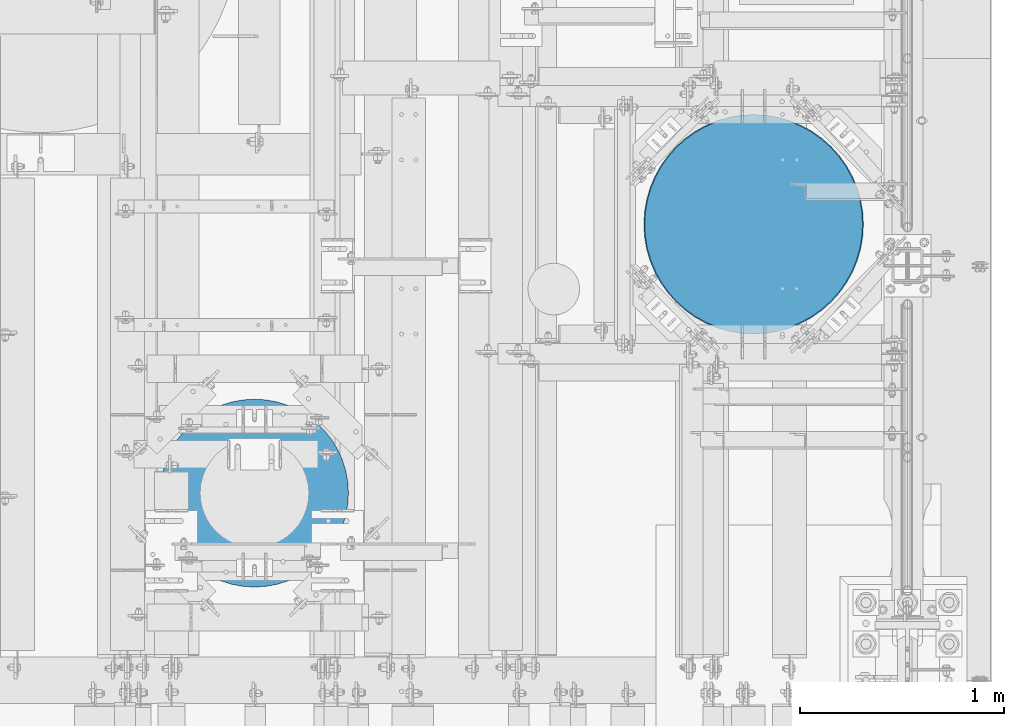
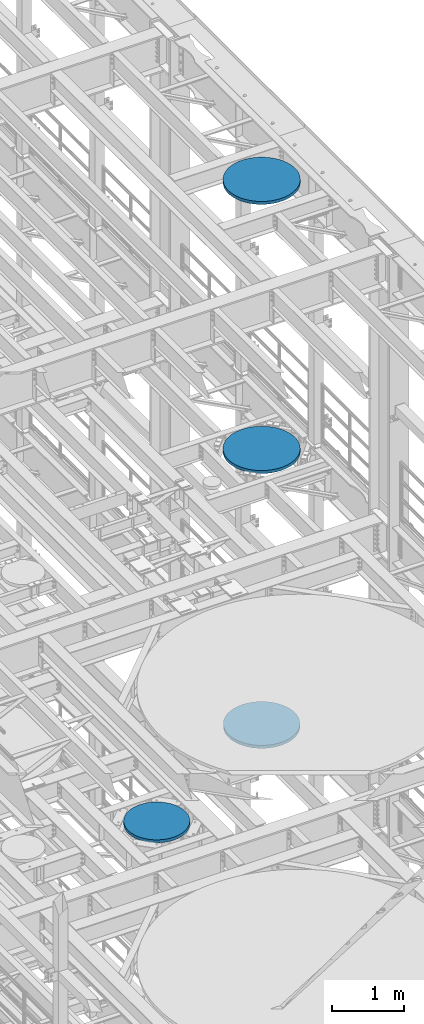
# One storey, part 704 of 1876: 4 columns, 4 elements without a shape of their own.
"""IFC2X3 building model written with IfcOpenShell, lengths in millimetres."""

from ifc_helpers import new_model, si_unit, frame, origin_with_axes, place, context, subcontext, project, spatial, faceted_brep, material, type_object, element, aggregate, save


model = new_model("IFC2X3")

# Units and contexts
model_context = context("Model", 3, precision=1e-05, world=origin_with_axes())
body_context = subcontext(model_context, "Body", "Model", "MODEL_VIEW")
ifc_project = project(units=[si_unit("LENGTHUNIT", "METRE", prefix="MILLI"), si_unit("AREAUNIT", "SQUARE_METRE"), si_unit("VOLUMEUNIT", "CUBIC_METRE"), si_unit("MASSUNIT", "GRAM", prefix="KILO"), si_unit("TIMEUNIT", "SECOND"), si_unit("PLANEANGLEUNIT", "RADIAN"), si_unit("SOLIDANGLEUNIT", "STERADIAN"), si_unit("THERMODYNAMICTEMPERATUREUNIT", "DEGREE_CELSIUS"), si_unit("LUMINOUSINTENSITYUNIT", "LUMEN")], contexts=[model_context])

# Site, building, storey
site_placement = place(None, origin_with_axes())
site = spatial("IfcSite", under=ifc_project, at=site_placement, CompositionType="ELEMENT")
building_placement = place(site_placement, origin_with_axes())
building = spatial("IfcBuilding", under=site, at=building_placement, Name="Undefined", CompositionType="ELEMENT")
storey_placement = place(building_placement, origin_with_axes())
storey = spatial("IfcBuildingStorey", under=building, at=storey_placement, Name="Undefined", CompositionType="ELEMENT", Elevation=0.0)

# Assembly, column
assembly_1_placement = place(storey_placement, origin_with_axes())
assembly_1 = element("IfcElementAssembly", 1, at=assembly_1_placement, inside=storey, Name="COLUMN", AssemblyPlace="NOTDEFINED", PredefinedType="REINFORCEMENT_UNIT")
ifc_material = material(Name="CONCRETE/3000")
column_type_1 = type_object("IfcColumnType", PredefinedType="NOTDEFINED")
column_1_placement = place(assembly_1_placement, frame((6865.93749999365, 3759.19999694327, 22529.8), z_axis=(-1.0, 0.0, 0.0), x_axis=(0.0, 0.0, 1.0)))
column_1 = element("IfcColumn", 2, at=column_1_placement, type_object=column_type_1, material=ifc_material, Name="COLUMN", context=body_context, shape_type="Brep", body=[
    faceted_brep([(0.0, -538.1625, 0.0), (0.0, -534.778647156672, -60.2550823709462), (50.7999999999993, -534.778647156672, -60.2550823709462), (50.7999999999993, -538.1625, 0.0), (0.0, -524.669642539551, -119.752422120265), (50.7999999999993, -524.669642539551, -119.752422120265), (0.0, -507.962612747077, -177.743805679448), (50.7999999999993, -507.962612747077, -177.743805679448), (0.0, -484.867658372536, -233.499957752853), (50.7999999999993, -484.867658372536, -233.499957752853), (0.0, -455.675211867192, -286.319712377684), (50.7999999999993, -455.675211867192, -286.319712377684), (0.0, -420.752385183701, -335.538830492801), (50.7999999999993, -420.752385183701, -335.538830492801), (0.0, -380.538353130305, -380.538353130305), (50.7999999999993, -380.538353130305, -380.538353130305), (0.0, -335.538830492801, -420.752385183701), (50.7999999999993, -335.538830492801, -420.752385183701), (0.0, -286.319712377684, -455.675211867191), (50.7999999999993, -286.319712377684, -455.675211867191), (0.0, -233.499957752853, -484.867658372536), (50.7999999999993, -233.499957752853, -484.867658372536), (0.0, -177.743805679448, -507.962612747076), (50.7999999999993, -177.743805679448, -507.962612747076), (0.0, -119.752422120265, -524.66964253955), (50.7999999999993, -119.752422120265, -524.66964253955), (0.0, -60.2550823709462, -534.778647156672), (50.7999999999993, -60.2550823709462, -534.778647156672), (0.0, 0.0, -538.1625), (50.7999999999993, 0.0, -538.1625), (0.0, 60.2550823709466, -534.778647156672), (50.7999999999993, 60.2550823709466, -534.778647156672), (0.0, 119.752422120265, -524.66964253955), (50.7999999999993, 119.752422120265, -524.66964253955), (0.0, 177.743805679448, -507.962612747076), (50.7999999999993, 177.743805679448, -507.962612747076), (0.0, 233.499957752853, -484.867658372536), (50.7999999999993, 233.499957752853, -484.867658372536), (0.0, 286.319712377685, -455.675211867191), (50.7999999999993, 286.319712377685, -455.675211867191), (0.0, 335.538830492801, -420.752385183701), (50.7999999999993, 335.538830492801, -420.752385183701), (0.0, 380.538353130305, -380.538353130305), (50.7999999999993, 380.538353130305, -380.538353130305), (0.0, 420.752385183701, -335.538830492801), (50.7999999999993, 420.752385183701, -335.538830492801), (0.0, 455.675211867191, -286.319712377684), (50.7999999999993, 455.675211867191, -286.319712377684), (0.0, 484.867658372536, -233.499957752852), (50.7999999999993, 484.867658372536, -233.499957752852), (0.0, 507.962612747076, -177.743805679447), (50.7999999999993, 507.962612747076, -177.743805679447), (0.0, 524.66964253955, -119.752422120265), (50.7999999999993, 524.66964253955, -119.752422120265), (0.0, 534.778647156672, -60.2550823709462), (50.7999999999993, 534.778647156672, -60.2550823709462), (0.0, 538.1625, 0.0), (50.7999999999993, 538.1625, 0.0), (0.0, 534.778647156672, 60.2550823709462), (50.7999999999993, 534.778647156672, 60.2550823709462), (0.0, 524.66964253955, 119.752422120265), (50.7999999999993, 524.66964253955, 119.752422120265), (0.0, 507.962612747076, 177.743805679448), (50.7999999999993, 507.962612747076, 177.743805679448), (0.0, 484.867658372536, 233.499957752853), (50.7999999999993, 484.867658372536, 233.499957752853), (0.0, 455.675211867191, 286.319712377684), (50.7999999999993, 455.675211867191, 286.319712377684), (0.0, 420.752385183701, 335.538830492801), (50.7999999999993, 420.752385183701, 335.538830492801), (0.0, 380.538353130305, 380.538353130305), (50.7999999999993, 380.538353130305, 380.538353130305), (0.0, 335.538830492801, 420.752385183701), (50.7999999999993, 335.538830492801, 420.752385183701), (0.0, 286.319712377685, 455.675211867191), (50.7999999999993, 286.319712377685, 455.675211867191), (0.0, 233.499957752853, 484.867658372536), (50.7999999999993, 233.499957752853, 484.867658372536), (0.0, 177.743805679448, 507.962612747076), (50.7999999999993, 177.743805679448, 507.962612747076), (0.0, 119.752422120265, 524.66964253955), (50.7999999999993, 119.752422120265, 524.66964253955), (0.0, 60.2550823709462, 534.778647156672), (50.7999999999993, 60.2550823709462, 534.778647156672), (0.0, 0.0, 538.1625), (50.7999999999993, 0.0, 538.1625), (0.0, -60.2550823709466, 534.778647156672), (50.7999999999993, -60.2550823709466, 534.778647156672), (0.0, -119.752422120265, 524.66964253955), (50.7999999999993, -119.752422120265, 524.66964253955), (0.0, -177.743805679448, 507.962612747076), (50.7999999999993, -177.743805679448, 507.962612747076), (0.0, -233.499957752853, 484.867658372536), (50.7999999999993, -233.499957752853, 484.867658372536), (0.0, -286.319712377685, 455.675211867191), (50.7999999999993, -286.319712377685, 455.675211867191), (0.0, -335.538830492801, 420.752385183701), (50.7999999999993, -335.538830492801, 420.752385183701), (0.0, -380.538353130305, 380.538353130305), (50.7999999999993, -380.538353130305, 380.538353130305), (0.0, -420.752385183701, 335.538830492801), (50.7999999999993, -420.752385183701, 335.538830492801), (0.0, -455.675211867192, 286.319712377684), (50.7999999999993, -455.675211867192, 286.319712377684), (0.0, -484.867658372536, 233.499957752852), (50.7999999999993, -484.867658372536, 233.499957752852), (0.0, -507.962612747077, 177.743805679447), (50.7999999999993, -507.962612747077, 177.743805679447), (0.0, -524.669642539551, 119.752422120265), (50.7999999999993, -524.669642539551, 119.752422120265), (0.0, -534.778647156672, 60.2550823709462), (50.7999999999993, -534.778647156672, 60.2550823709462)], [[[0, 1, 2, 3]], [[1, 4, 5, 2]], [[4, 6, 7, 5]], [[6, 8, 9, 7]], [[8, 10, 11, 9]], [[10, 12, 13, 11]], [[12, 14, 15, 13]], [[14, 16, 17, 15]], [[16, 18, 19, 17]], [[18, 20, 21, 19]], [[20, 22, 23, 21]], [[22, 24, 25, 23]], [[24, 26, 27, 25]], [[26, 28, 29, 27]], [[28, 30, 31, 29]], [[30, 32, 33, 31]], [[32, 34, 35, 33]], [[34, 36, 37, 35]], [[36, 38, 39, 37]], [[38, 40, 41, 39]], [[40, 42, 43, 41]], [[42, 44, 45, 43]], [[44, 46, 47, 45]], [[46, 48, 49, 47]], [[48, 50, 51, 49]], [[50, 52, 53, 51]], [[52, 54, 55, 53]], [[54, 56, 57, 55]], [[56, 58, 59, 57]], [[58, 60, 61, 59]], [[60, 62, 63, 61]], [[62, 64, 65, 63]], [[64, 66, 67, 65]], [[66, 68, 69, 67]], [[68, 70, 71, 69]], [[70, 72, 73, 71]], [[72, 74, 75, 73]], [[74, 76, 77, 75]], [[76, 78, 79, 77]], [[78, 80, 81, 79]], [[80, 82, 83, 81]], [[82, 84, 85, 83]], [[84, 86, 87, 85]], [[86, 88, 89, 87]], [[88, 90, 91, 89]], [[90, 92, 93, 91]], [[92, 94, 95, 93]], [[94, 96, 97, 95]], [[96, 98, 99, 97]], [[98, 100, 101, 99]], [[100, 102, 103, 101]], [[102, 104, 105, 103]], [[104, 106, 107, 105]], [[106, 108, 109, 107]], [[108, 110, 111, 109]], [[110, 0, 3, 111]], [[5, 7, 9, 11, 13, 15, 17, 19, 21, 23, 25, 27, 29, 31, 33, 35, 37, 39, 41, 43, 45, 47, 49, 51, 53, 55, 57, 59, 61, 63, 65, 67, 69, 71, 73, 75, 77, 79, 81, 83, 85, 87, 89, 91, 93, 95, 97, 99, 101, 103, 105, 107, 109, 111, 3, 2]], [[110, 108, 106, 104, 102, 100, 98, 96, 94, 92, 90, 88, 86, 84, 82, 80, 78, 76, 74, 72, 70, 68, 66, 64, 62, 60, 58, 56, 54, 52, 50, 48, 46, 44, 42, 40, 38, 36, 34, 32, 30, 28, 26, 24, 22, 20, 18, 16, 14, 12, 10, 8, 6, 4, 1, 0]]]),
])
aggregate(assembly_1, [column_1])

assembly_2_placement = place(storey_placement, origin_with_axes())
assembly_2 = element("IfcElementAssembly", 3, at=assembly_2_placement, inside=storey, Name="COLUMN", AssemblyPlace="NOTDEFINED", PredefinedType="REINFORCEMENT_UNIT")
column_2_placement = place(assembly_2_placement, frame((6865.93749999365, 3759.19999694327, 17957.8), z_axis=(-1.0, 0.0, 0.0), x_axis=(0.0, 0.0, 1.0)))
column_2 = element("IfcColumn", 4, at=column_2_placement, type_object=column_type_1, material=ifc_material, Name="COLUMN", context=body_context, shape_type="Brep", body=[
    faceted_brep([(0.0, -538.1625, 0.0), (0.0, -534.778647156672, -60.2550823709462), (50.7999999999993, -534.778647156672, -60.2550823709462), (50.7999999999993, -538.1625, 0.0), (0.0, -524.669642539551, -119.752422120265), (50.7999999999993, -524.669642539551, -119.752422120265), (0.0, -507.962612747077, -177.743805679448), (50.7999999999993, -507.962612747077, -177.743805679448), (0.0, -484.867658372536, -233.499957752853), (50.7999999999993, -484.867658372536, -233.499957752853), (0.0, -455.675211867192, -286.319712377684), (50.7999999999993, -455.675211867192, -286.319712377684), (0.0, -420.752385183701, -335.538830492801), (50.7999999999993, -420.752385183701, -335.538830492801), (0.0, -380.538353130305, -380.538353130305), (50.7999999999993, -380.538353130305, -380.538353130305), (0.0, -335.538830492801, -420.752385183701), (50.7999999999993, -335.538830492801, -420.752385183701), (0.0, -286.319712377684, -455.675211867191), (50.7999999999993, -286.319712377684, -455.675211867191), (0.0, -233.499957752853, -484.867658372536), (50.7999999999993, -233.499957752853, -484.867658372536), (0.0, -177.743805679448, -507.962612747076), (50.7999999999993, -177.743805679448, -507.962612747076), (0.0, -119.752422120265, -524.66964253955), (50.7999999999993, -119.752422120265, -524.66964253955), (0.0, -60.2550823709462, -534.778647156672), (50.7999999999993, -60.2550823709462, -534.778647156672), (0.0, 0.0, -538.1625), (50.7999999999993, 0.0, -538.1625), (0.0, 60.2550823709466, -534.778647156672), (50.7999999999993, 60.2550823709466, -534.778647156672), (0.0, 119.752422120265, -524.66964253955), (50.7999999999993, 119.752422120265, -524.66964253955), (0.0, 177.743805679448, -507.962612747076), (50.7999999999993, 177.743805679448, -507.962612747076), (0.0, 233.499957752853, -484.867658372536), (50.7999999999993, 233.499957752853, -484.867658372536), (0.0, 286.319712377685, -455.675211867191), (50.7999999999993, 286.319712377685, -455.675211867191), (0.0, 335.538830492801, -420.752385183701), (50.7999999999993, 335.538830492801, -420.752385183701), (0.0, 380.538353130305, -380.538353130305), (50.7999999999993, 380.538353130305, -380.538353130305), (0.0, 420.752385183701, -335.538830492801), (50.7999999999993, 420.752385183701, -335.538830492801), (0.0, 455.675211867191, -286.319712377684), (50.7999999999993, 455.675211867191, -286.319712377684), (0.0, 484.867658372536, -233.499957752852), (50.7999999999993, 484.867658372536, -233.499957752852), (0.0, 507.962612747076, -177.743805679447), (50.7999999999993, 507.962612747076, -177.743805679447), (0.0, 524.66964253955, -119.752422120265), (50.7999999999993, 524.66964253955, -119.752422120265), (0.0, 534.778647156672, -60.2550823709462), (50.7999999999993, 534.778647156672, -60.2550823709462), (0.0, 538.1625, 0.0), (50.7999999999993, 538.1625, 0.0), (0.0, 534.778647156672, 60.2550823709462), (50.7999999999993, 534.778647156672, 60.2550823709462), (0.0, 524.66964253955, 119.752422120265), (50.7999999999993, 524.66964253955, 119.752422120265), (0.0, 507.962612747076, 177.743805679448), (50.7999999999993, 507.962612747076, 177.743805679448), (0.0, 484.867658372536, 233.499957752853), (50.7999999999993, 484.867658372536, 233.499957752853), (0.0, 455.675211867191, 286.319712377684), (50.7999999999993, 455.675211867191, 286.319712377684), (0.0, 420.752385183701, 335.538830492801), (50.7999999999993, 420.752385183701, 335.538830492801), (0.0, 380.538353130305, 380.538353130305), (50.7999999999993, 380.538353130305, 380.538353130305), (0.0, 335.538830492801, 420.752385183701), (50.7999999999993, 335.538830492801, 420.752385183701), (0.0, 286.319712377685, 455.675211867191), (50.7999999999993, 286.319712377685, 455.675211867191), (0.0, 233.499957752853, 484.867658372536), (50.7999999999993, 233.499957752853, 484.867658372536), (0.0, 177.743805679448, 507.962612747076), (50.7999999999993, 177.743805679448, 507.962612747076), (0.0, 119.752422120265, 524.66964253955), (50.7999999999993, 119.752422120265, 524.66964253955), (0.0, 60.2550823709462, 534.778647156672), (50.7999999999993, 60.2550823709462, 534.778647156672), (0.0, 0.0, 538.1625), (50.7999999999993, 0.0, 538.1625), (0.0, -60.2550823709466, 534.778647156672), (50.7999999999993, -60.2550823709466, 534.778647156672), (0.0, -119.752422120265, 524.66964253955), (50.7999999999993, -119.752422120265, 524.66964253955), (0.0, -177.743805679448, 507.962612747076), (50.7999999999993, -177.743805679448, 507.962612747076), (0.0, -233.499957752853, 484.867658372536), (50.7999999999993, -233.499957752853, 484.867658372536), (0.0, -286.319712377685, 455.675211867191), (50.7999999999993, -286.319712377685, 455.675211867191), (0.0, -335.538830492801, 420.752385183701), (50.7999999999993, -335.538830492801, 420.752385183701), (0.0, -380.538353130305, 380.538353130305), (50.7999999999993, -380.538353130305, 380.538353130305), (0.0, -420.752385183701, 335.538830492801), (50.7999999999993, -420.752385183701, 335.538830492801), (0.0, -455.675211867192, 286.319712377684), (50.7999999999993, -455.675211867192, 286.319712377684), (0.0, -484.867658372536, 233.499957752852), (50.7999999999993, -484.867658372536, 233.499957752852), (0.0, -507.962612747077, 177.743805679447), (50.7999999999993, -507.962612747077, 177.743805679447), (0.0, -524.669642539551, 119.752422120265), (50.7999999999993, -524.669642539551, 119.752422120265), (0.0, -534.778647156672, 60.2550823709462), (50.7999999999993, -534.778647156672, 60.2550823709462)], [[[0, 1, 2, 3]], [[1, 4, 5, 2]], [[4, 6, 7, 5]], [[6, 8, 9, 7]], [[8, 10, 11, 9]], [[10, 12, 13, 11]], [[12, 14, 15, 13]], [[14, 16, 17, 15]], [[16, 18, 19, 17]], [[18, 20, 21, 19]], [[20, 22, 23, 21]], [[22, 24, 25, 23]], [[24, 26, 27, 25]], [[26, 28, 29, 27]], [[28, 30, 31, 29]], [[30, 32, 33, 31]], [[32, 34, 35, 33]], [[34, 36, 37, 35]], [[36, 38, 39, 37]], [[38, 40, 41, 39]], [[40, 42, 43, 41]], [[42, 44, 45, 43]], [[44, 46, 47, 45]], [[46, 48, 49, 47]], [[48, 50, 51, 49]], [[50, 52, 53, 51]], [[52, 54, 55, 53]], [[54, 56, 57, 55]], [[56, 58, 59, 57]], [[58, 60, 61, 59]], [[60, 62, 63, 61]], [[62, 64, 65, 63]], [[64, 66, 67, 65]], [[66, 68, 69, 67]], [[68, 70, 71, 69]], [[70, 72, 73, 71]], [[72, 74, 75, 73]], [[74, 76, 77, 75]], [[76, 78, 79, 77]], [[78, 80, 81, 79]], [[80, 82, 83, 81]], [[82, 84, 85, 83]], [[84, 86, 87, 85]], [[86, 88, 89, 87]], [[88, 90, 91, 89]], [[90, 92, 93, 91]], [[92, 94, 95, 93]], [[94, 96, 97, 95]], [[96, 98, 99, 97]], [[98, 100, 101, 99]], [[100, 102, 103, 101]], [[102, 104, 105, 103]], [[104, 106, 107, 105]], [[106, 108, 109, 107]], [[108, 110, 111, 109]], [[110, 0, 3, 111]], [[5, 7, 9, 11, 13, 15, 17, 19, 21, 23, 25, 27, 29, 31, 33, 35, 37, 39, 41, 43, 45, 47, 49, 51, 53, 55, 57, 59, 61, 63, 65, 67, 69, 71, 73, 75, 77, 79, 81, 83, 85, 87, 89, 91, 93, 95, 97, 99, 101, 103, 105, 107, 109, 111, 3, 2]], [[110, 108, 106, 104, 102, 100, 98, 96, 94, 92, 90, 88, 86, 84, 82, 80, 78, 76, 74, 72, 70, 68, 66, 64, 62, 60, 58, 56, 54, 52, 50, 48, 46, 44, 42, 40, 38, 36, 34, 32, 30, 28, 26, 24, 22, 20, 18, 16, 14, 12, 10, 8, 6, 4, 1, 0]]]),
])
aggregate(assembly_2, [column_2])

assembly_3_placement = place(storey_placement, origin_with_axes())
assembly_3 = element("IfcElementAssembly", 5, at=assembly_3_placement, inside=storey, Name="COLUMN", AssemblyPlace="NOTDEFINED", PredefinedType="REINFORCEMENT_UNIT")
column_type_2 = type_object("IfcColumnType", PredefinedType="NOTDEFINED")
column_3_placement = place(assembly_3_placement, frame((6865.9375, 3759.2, 13284.2), z_axis=(-1.0, 0.0, 0.0), x_axis=(0.0, 0.0, 1.0)))
column_3 = element("IfcColumn", 6, at=column_3_placement, type_object=column_type_2, material=ifc_material, Name="COLUMN", context=body_context, shape_type="Brep", body=[
    faceted_brep([(0.0, -533.4, 0.0), (0.0, -530.046092757056, -59.7218515535042), (50.7999999999993, -530.046092757056, -59.7218515535042), (50.7999999999993, -533.4, 0.0), (0.0, -520.026548357785, -118.692666172298), (50.7999999999993, -520.026548357785, -118.692666172298), (0.0, -503.467368386483, -176.170851646886), (50.7999999999993, -503.467368386483, -176.170851646886), (0.0, -480.57679413915, -231.433586445306), (50.7999999999993, -480.57679413915, -231.433586445306), (0.0, -451.642687868366, -283.785909613281), (50.7999999999993, -451.642687868366, -283.785909613281), (0.0, -417.028912748447, -332.569460311449), (50.7999999999993, -417.028912748447, -332.569460311449), (0.0, -377.170757084904, -377.170757084905), (50.7999999999993, -377.170757084904, -377.170757084905), (0.0, -332.569460311448, -417.028912748448), (50.7999999999993, -332.569460311448, -417.028912748448), (0.0, -283.78590961328, -451.642687868367), (50.7999999999993, -283.78590961328, -451.642687868367), (0.0, -231.433586445306, -480.57679413915), (50.7999999999993, -231.433586445306, -480.57679413915), (0.0, -176.170851646886, -503.467368386483), (50.7999999999993, -176.170851646886, -503.467368386483), (0.0, -118.692666172298, -520.026548357785), (50.7999999999993, -118.692666172298, -520.026548357785), (0.0, -59.7218515535042, -530.046092757056), (50.7999999999993, -59.7218515535042, -530.046092757056), (0.0, 0.0, -533.4), (50.7999999999993, 0.0, -533.4), (0.0, 59.7218515535046, -530.046092757056), (50.7999999999993, 59.7218515535046, -530.046092757056), (0.0, 118.692666172298, -520.026548357785), (50.7999999999993, 118.692666172298, -520.026548357785), (0.0, 176.170851646886, -503.467368386483), (50.7999999999993, 176.170851646886, -503.467368386483), (0.0, 231.433586445306, -480.57679413915), (50.7999999999993, 231.433586445306, -480.57679413915), (0.0, 283.785909613281, -451.642687868367), (50.7999999999993, 283.785909613281, -451.642687868367), (0.0, 332.569460311448, -417.028912748447), (50.7999999999993, 332.569460311448, -417.028912748447), (0.0, 377.170757084904, -377.170757084905), (50.7999999999993, 377.170757084904, -377.170757084905), (0.0, 417.028912748447, -332.569460311448), (50.7999999999993, 417.028912748447, -332.569460311448), (0.0, 451.642687868366, -283.785909613281), (50.7999999999993, 451.642687868366, -283.785909613281), (0.0, 480.57679413915, -231.433586445305), (50.7999999999993, 480.57679413915, -231.433586445305), (0.0, 503.467368386483, -176.170851646886), (50.7999999999993, 503.467368386483, -176.170851646886), (0.0, 520.026548357785, -118.692666172298), (50.7999999999993, 520.026548357785, -118.692666172298), (0.0, 530.046092757055, -59.7218515535042), (50.7999999999993, 530.046092757055, -59.7218515535042), (0.0, 533.4, 0.0), (50.7999999999993, 533.4, 0.0), (0.0, 530.046092757055, 59.7218515535042), (50.7999999999993, 530.046092757055, 59.7218515535042), (0.0, 520.026548357785, 118.692666172298), (50.7999999999993, 520.026548357785, 118.692666172298), (0.0, 503.467368386483, 176.170851646886), (50.7999999999993, 503.467368386483, 176.170851646886), (0.0, 480.57679413915, 231.433586445306), (50.7999999999993, 480.57679413915, 231.433586445306), (0.0, 451.642687868366, 283.785909613281), (50.7999999999993, 451.642687868366, 283.785909613281), (0.0, 417.028912748447, 332.569460311449), (50.7999999999993, 417.028912748447, 332.569460311449), (0.0, 377.170757084904, 377.170757084905), (50.7999999999993, 377.170757084904, 377.170757084905), (0.0, 332.569460311448, 417.028912748448), (50.7999999999993, 332.569460311448, 417.028912748448), (0.0, 283.785909613281, 451.642687868367), (50.7999999999993, 283.785909613281, 451.642687868367), (0.0, 231.433586445306, 480.57679413915), (50.7999999999993, 231.433586445306, 480.57679413915), (0.0, 176.170851646886, 503.467368386483), (50.7999999999993, 176.170851646886, 503.467368386483), (0.0, 118.692666172298, 520.026548357785), (50.7999999999993, 118.692666172298, 520.026548357785), (0.0, 59.7218515535042, 530.046092757056), (50.7999999999993, 59.7218515535042, 530.046092757056), (0.0, 0.0, 533.4), (50.7999999999993, 0.0, 533.4), (0.0, -59.7218515535046, 530.046092757056), (50.7999999999993, -59.7218515535046, 530.046092757056), (0.0, -118.692666172298, 520.026548357785), (50.7999999999993, -118.692666172298, 520.026548357785), (0.0, -176.170851646886, 503.467368386483), (50.7999999999993, -176.170851646886, 503.467368386483), (0.0, -231.433586445306, 480.57679413915), (50.7999999999993, -231.433586445306, 480.57679413915), (0.0, -283.785909613281, 451.642687868367), (50.7999999999993, -283.785909613281, 451.642687868367), (0.0, -332.569460311448, 417.028912748447), (50.7999999999993, -332.569460311448, 417.028912748447), (0.0, -377.170757084904, 377.170757084905), (50.7999999999993, -377.170757084904, 377.170757084905), (0.0, -417.028912748447, 332.569460311448), (50.7999999999993, -417.028912748447, 332.569460311448), (0.0, -451.642687868367, 283.785909613281), (50.7999999999993, -451.642687868367, 283.785909613281), (0.0, -480.57679413915, 231.433586445305), (50.7999999999993, -480.57679413915, 231.433586445305), (0.0, -503.467368386483, 176.170851646886), (50.7999999999993, -503.467368386483, 176.170851646886), (0.0, -520.026548357785, 118.692666172298), (50.7999999999993, -520.026548357785, 118.692666172298), (0.0, -530.046092757056, 59.7218515535042), (50.7999999999993, -530.046092757056, 59.7218515535042)], [[[0, 1, 2, 3]], [[1, 4, 5, 2]], [[4, 6, 7, 5]], [[6, 8, 9, 7]], [[8, 10, 11, 9]], [[10, 12, 13, 11]], [[12, 14, 15, 13]], [[14, 16, 17, 15]], [[16, 18, 19, 17]], [[18, 20, 21, 19]], [[20, 22, 23, 21]], [[22, 24, 25, 23]], [[24, 26, 27, 25]], [[26, 28, 29, 27]], [[28, 30, 31, 29]], [[30, 32, 33, 31]], [[32, 34, 35, 33]], [[34, 36, 37, 35]], [[36, 38, 39, 37]], [[38, 40, 41, 39]], [[40, 42, 43, 41]], [[42, 44, 45, 43]], [[44, 46, 47, 45]], [[46, 48, 49, 47]], [[48, 50, 51, 49]], [[50, 52, 53, 51]], [[52, 54, 55, 53]], [[54, 56, 57, 55]], [[56, 58, 59, 57]], [[58, 60, 61, 59]], [[60, 62, 63, 61]], [[62, 64, 65, 63]], [[64, 66, 67, 65]], [[66, 68, 69, 67]], [[68, 70, 71, 69]], [[70, 72, 73, 71]], [[72, 74, 75, 73]], [[74, 76, 77, 75]], [[76, 78, 79, 77]], [[78, 80, 81, 79]], [[80, 82, 83, 81]], [[82, 84, 85, 83]], [[84, 86, 87, 85]], [[86, 88, 89, 87]], [[88, 90, 91, 89]], [[90, 92, 93, 91]], [[92, 94, 95, 93]], [[94, 96, 97, 95]], [[96, 98, 99, 97]], [[98, 100, 101, 99]], [[100, 102, 103, 101]], [[102, 104, 105, 103]], [[104, 106, 107, 105]], [[106, 108, 109, 107]], [[108, 110, 111, 109]], [[110, 0, 3, 111]], [[5, 7, 9, 11, 13, 15, 17, 19, 21, 23, 25, 27, 29, 31, 33, 35, 37, 39, 41, 43, 45, 47, 49, 51, 53, 55, 57, 59, 61, 63, 65, 67, 69, 71, 73, 75, 77, 79, 81, 83, 85, 87, 89, 91, 93, 95, 97, 99, 101, 103, 105, 107, 109, 111, 3, 2]], [[110, 108, 106, 104, 102, 100, 98, 96, 94, 92, 90, 88, 86, 84, 82, 80, 78, 76, 74, 72, 70, 68, 66, 64, 62, 60, 58, 56, 54, 52, 50, 48, 46, 44, 42, 40, 38, 36, 34, 32, 30, 28, 26, 24, 22, 20, 18, 16, 14, 12, 10, 8, 6, 4, 1, 0]]]),
])
aggregate(assembly_3, [column_3])

assembly_4_placement = place(storey_placement, origin_with_axes())
assembly_4 = element("IfcElementAssembly", 7, at=assembly_4_placement, inside=storey, Name="COLUMN", AssemblyPlace="NOTDEFINED", PredefinedType="REINFORCEMENT_UNIT")
column_type_3 = type_object("IfcColumnType", PredefinedType="NOTDEFINED")
column_4_placement = place(assembly_4_placement, frame((4419.6, 2441.575, 13284.2), z_axis=(-1.0, 0.0, 0.0), x_axis=(0.0, 0.0, 1.0)))
column_4 = element("IfcColumn", 8, at=column_4_placement, type_object=column_type_3, material=ifc_material, Name="COLUMN", context=body_context, shape_type="Brep", body=[
    faceted_brep([(0.0, -460.375, 0.0), (0.0, -457.018347912892, -55.4920741725446), (50.7999999999993, -457.018347912892, -55.4920741725446), (50.7999999999993, -460.375, 0.0), (0.0, -446.997339197519, -110.174948946385), (50.7999999999993, -446.997339197519, -110.174948946385), (0.0, -430.458102726298, -163.251224872208), (50.7999999999993, -430.458102726298, -163.251224872208), (0.0, -407.641817810096, -213.94693032965), (50.7999999999993, -407.641817810096, -213.94693032965), (0.0, -378.881197260792, -261.522807776356), (50.7999999999993, -378.881197260792, -261.522807776356), (0.0, -344.595635689271, -305.285093787606), (50.7999999999993, -344.595635689271, -305.285093787606), (0.0, -305.285093787606, -344.595635689271), (50.7999999999993, -305.285093787606, -344.595635689271), (0.0, -261.522807776356, -378.881197260792), (50.7999999999993, -261.522807776356, -378.881197260792), (0.0, -213.94693032965, -407.641817810097), (50.7999999999993, -213.94693032965, -407.641817810097), (0.0, -163.251224872207, -430.458102726298), (50.7999999999993, -163.251224872207, -430.458102726298), (0.0, -110.174948946384, -446.997339197519), (50.7999999999993, -110.174948946384, -446.997339197519), (0.0, -55.4920741725441, -457.018347912892), (50.7999999999993, -55.4920741725441, -457.018347912892), (0.0, 0.0, -460.375), (50.7999999999993, 0.0, -460.375), (0.0, 55.4920741725446, -457.018347912892), (50.7999999999993, 55.4920741725446, -457.018347912892), (0.0, 110.174948946385, -446.997339197519), (50.7999999999993, 110.174948946385, -446.997339197519), (0.0, 163.251224872207, -430.458102726298), (50.7999999999993, 163.251224872207, -430.458102726298), (0.0, 213.94693032965, -407.641817810097), (50.7999999999993, 213.94693032965, -407.641817810097), (0.0, 261.522807776356, -378.881197260792), (50.7999999999993, 261.522807776356, -378.881197260792), (0.0, 305.285093787606, -344.59563568927), (50.7999999999993, 305.285093787606, -344.59563568927), (0.0, 344.595635689271, -305.285093787606), (50.7999999999993, 344.595635689271, -305.285093787606), (0.0, 378.881197260792, -261.522807776356), (50.7999999999993, 378.881197260792, -261.522807776356), (0.0, 407.641817810097, -213.94693032965), (50.7999999999993, 407.641817810097, -213.94693032965), (0.0, 430.458102726298, -163.251224872207), (50.7999999999993, 430.458102726298, -163.251224872207), (0.0, 446.997339197519, -110.174948946385), (50.7999999999993, 446.997339197519, -110.174948946385), (0.0, 457.018347912892, -55.4920741725446), (50.7999999999993, 457.018347912892, -55.4920741725446), (0.0, 460.375, 0.0), (50.7999999999993, 460.375, 0.0), (0.0, 457.018347912892, 55.4920741725446), (50.7999999999993, 457.018347912892, 55.4920741725446), (0.0, 446.997339197519, 110.174948946385), (50.7999999999993, 446.997339197519, 110.174948946385), (0.0, 430.458102726298, 163.251224872208), (50.7999999999993, 430.458102726298, 163.251224872208), (0.0, 407.641817810097, 213.94693032965), (50.7999999999993, 407.641817810097, 213.94693032965), (0.0, 378.881197260792, 261.522807776356), (50.7999999999993, 378.881197260792, 261.522807776356), (0.0, 344.595635689271, 305.285093787606), (50.7999999999993, 344.595635689271, 305.285093787606), (0.0, 305.285093787606, 344.595635689271), (50.7999999999993, 305.285093787606, 344.595635689271), (0.0, 261.522807776356, 378.881197260792), (50.7999999999993, 261.522807776356, 378.881197260792), (0.0, 213.94693032965, 407.641817810097), (50.7999999999993, 213.94693032965, 407.641817810097), (0.0, 163.251224872207, 430.458102726298), (50.7999999999993, 163.251224872207, 430.458102726298), (0.0, 110.174948946385, 446.997339197519), (50.7999999999993, 110.174948946385, 446.997339197519), (0.0, 55.4920741725441, 457.018347912892), (50.7999999999993, 55.4920741725441, 457.018347912892), (0.0, 0.0, 460.375), (50.7999999999993, 0.0, 460.375), (0.0, -55.4920741725446, 457.018347912892), (50.7999999999993, -55.4920741725446, 457.018347912892), (0.0, -110.174948946385, 446.997339197519), (50.7999999999993, -110.174948946385, 446.997339197519), (0.0, -163.251224872207, 430.458102726298), (50.7999999999993, -163.251224872207, 430.458102726298), (0.0, -213.94693032965, 407.641817810097), (50.7999999999993, -213.94693032965, 407.641817810097), (0.0, -261.522807776356, 378.881197260792), (50.7999999999993, -261.522807776356, 378.881197260792), (0.0, -305.285093787606, 344.595635689271), (50.7999999999993, -305.285093787606, 344.595635689271), (0.0, -344.595635689271, 305.285093787606), (50.7999999999993, -344.595635689271, 305.285093787606), (0.0, -378.881197260792, 261.522807776356), (50.7999999999993, -378.881197260792, 261.522807776356), (0.0, -407.641817810097, 213.94693032965), (50.7999999999993, -407.641817810097, 213.94693032965), (0.0, -430.458102726298, 163.251224872207), (50.7999999999993, -430.458102726298, 163.251224872207), (0.0, -446.997339197519, 110.174948946385), (50.7999999999993, -446.997339197519, 110.174948946385), (0.0, -457.018347912892, 55.4920741725446), (50.7999999999993, -457.018347912892, 55.4920741725446)], [[[0, 1, 2, 3]], [[1, 4, 5, 2]], [[4, 6, 7, 5]], [[6, 8, 9, 7]], [[8, 10, 11, 9]], [[10, 12, 13, 11]], [[12, 14, 15, 13]], [[14, 16, 17, 15]], [[16, 18, 19, 17]], [[18, 20, 21, 19]], [[20, 22, 23, 21]], [[22, 24, 25, 23]], [[24, 26, 27, 25]], [[26, 28, 29, 27]], [[28, 30, 31, 29]], [[30, 32, 33, 31]], [[32, 34, 35, 33]], [[34, 36, 37, 35]], [[36, 38, 39, 37]], [[38, 40, 41, 39]], [[40, 42, 43, 41]], [[42, 44, 45, 43]], [[44, 46, 47, 45]], [[46, 48, 49, 47]], [[48, 50, 51, 49]], [[50, 52, 53, 51]], [[52, 54, 55, 53]], [[54, 56, 57, 55]], [[56, 58, 59, 57]], [[58, 60, 61, 59]], [[60, 62, 63, 61]], [[62, 64, 65, 63]], [[64, 66, 67, 65]], [[66, 68, 69, 67]], [[68, 70, 71, 69]], [[70, 72, 73, 71]], [[72, 74, 75, 73]], [[74, 76, 77, 75]], [[76, 78, 79, 77]], [[78, 80, 81, 79]], [[80, 82, 83, 81]], [[82, 84, 85, 83]], [[84, 86, 87, 85]], [[86, 88, 89, 87]], [[88, 90, 91, 89]], [[90, 92, 93, 91]], [[92, 94, 95, 93]], [[94, 96, 97, 95]], [[96, 98, 99, 97]], [[98, 100, 101, 99]], [[100, 102, 103, 101]], [[102, 0, 3, 103]], [[5, 7, 9, 11, 13, 15, 17, 19, 21, 23, 25, 27, 29, 31, 33, 35, 37, 39, 41, 43, 45, 47, 49, 51, 53, 55, 57, 59, 61, 63, 65, 67, 69, 71, 73, 75, 77, 79, 81, 83, 85, 87, 89, 91, 93, 95, 97, 99, 101, 103, 3, 2]], [[102, 100, 98, 96, 94, 92, 90, 88, 86, 84, 82, 80, 78, 76, 74, 72, 70, 68, 66, 64, 62, 60, 58, 56, 54, 52, 50, 48, 46, 44, 42, 40, 38, 36, 34, 32, 30, 28, 26, 24, 22, 20, 18, 16, 14, 12, 10, 8, 6, 4, 1, 0]]]),
])
aggregate(assembly_4, [column_4])

save(model, "model.ifc")
